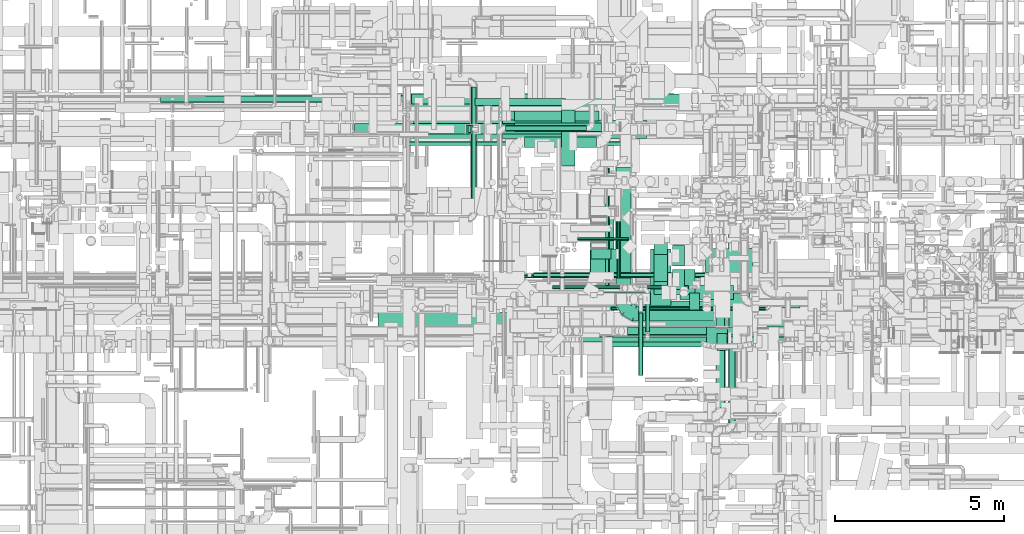
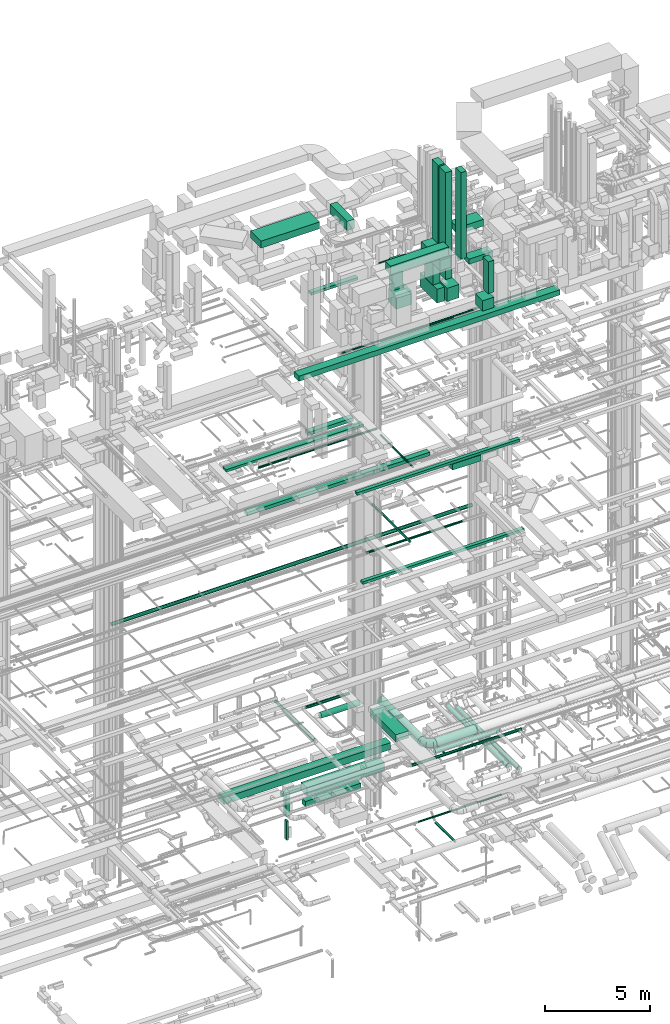
# One storey, part 43 of 337: 51 flow segments, 1 flow fitting.
"""IFC2X3 building model written with IfcOpenShell, lengths in millimetres."""

from ifc_helpers import new_model, entity, si_unit, converted_unit, derived_unit, direction, frame, origin, origin_2d_with_axis, place, context, subcontext, project, spatial, rectangle, circle, extrude, faceted_brep, source, transform, mapped, material, type_object, type_shapes, element, save


model = new_model("IFC2X3")

# Units and contexts
model_context = context("Model", 3, precision=0.01, world=origin(), true_north=direction((6.12303176911189e-17, 1.0)))
body_context = subcontext(model_context, "Body", "Model", "MODEL_VIEW")
ifc_project = project(units=[si_unit("LENGTHUNIT", "METRE", prefix="MILLI"), si_unit("AREAUNIT", "SQUARE_METRE"), si_unit("VOLUMEUNIT", "CUBIC_METRE"), converted_unit("PLANEANGLEUNIT", "DEGREE", entity("IfcRatioMeasure", 0.0174532925199433), si_unit("PLANEANGLEUNIT", "RADIAN"), dimensions=[0, 0, 0, 0, 0, 0, 0]), si_unit("MASSUNIT", "GRAM", prefix="KILO"), derived_unit("MASSDENSITYUNIT", [(si_unit("MASSUNIT", "GRAM", prefix="KILO"), 1), (si_unit("LENGTHUNIT", "METRE"), -3)]), derived_unit("MOMENTOFINERTIAUNIT", [(si_unit("LENGTHUNIT", "METRE"), 4)]), si_unit("TIMEUNIT", "SECOND"), si_unit("FREQUENCYUNIT", "HERTZ"), si_unit("THERMODYNAMICTEMPERATUREUNIT", "DEGREE_CELSIUS"), derived_unit("THERMALTRANSMITTANCEUNIT", [(si_unit("MASSUNIT", "GRAM", prefix="KILO"), 1), (si_unit("THERMODYNAMICTEMPERATUREUNIT", "KELVIN"), -1), (si_unit("TIMEUNIT", "SECOND"), -3)]), derived_unit("VOLUMETRICFLOWRATEUNIT", [(si_unit("LENGTHUNIT", "METRE"), 3), (si_unit("TIMEUNIT", "SECOND"), -1)]), derived_unit("MASSFLOWRATEUNIT", [(si_unit("MASSUNIT", "GRAM", prefix="KILO"), 1), (si_unit("TIMEUNIT", "SECOND"), -1)]), derived_unit("ROTATIONALFREQUENCYUNIT", [(si_unit("TIMEUNIT", "SECOND"), -1)]), si_unit("ELECTRICCURRENTUNIT", "AMPERE"), si_unit("ELECTRICVOLTAGEUNIT", "VOLT"), si_unit("POWERUNIT", "WATT"), si_unit("FORCEUNIT", "NEWTON", prefix="KILO"), si_unit("ILLUMINANCEUNIT", "LUX"), si_unit("LUMINOUSFLUXUNIT", "LUMEN"), si_unit("LUMINOUSINTENSITYUNIT", "CANDELA"), derived_unit("USERDEFINED", [(si_unit("MASSUNIT", "GRAM", prefix="KILO"), -1), (si_unit("LENGTHUNIT", "METRE"), -2), (si_unit("TIMEUNIT", "SECOND"), 3), (si_unit("LUMINOUSFLUXUNIT", "LUMEN"), 1)]), derived_unit("LINEARVELOCITYUNIT", [(si_unit("LENGTHUNIT", "METRE"), 1), (si_unit("TIMEUNIT", "SECOND"), -1)]), si_unit("PRESSUREUNIT", "PASCAL"), derived_unit("USERDEFINED", [(si_unit("LENGTHUNIT", "METRE"), -2), (si_unit("MASSUNIT", "GRAM", prefix="KILO"), 1), (si_unit("TIMEUNIT", "SECOND"), -2)]), derived_unit("LINEARFORCEUNIT", [(si_unit("MASSUNIT", "GRAM", prefix="KILO"), 1), (si_unit("LENGTHUNIT", "METRE"), 1), (si_unit("TIMEUNIT", "SECOND"), -2), (si_unit("LENGTHUNIT", "METRE"), -1)]), derived_unit("PLANARFORCEUNIT", [(si_unit("MASSUNIT", "GRAM", prefix="KILO"), 1), (si_unit("LENGTHUNIT", "METRE"), 1), (si_unit("TIMEUNIT", "SECOND"), -2), (si_unit("LENGTHUNIT", "METRE"), -2)])], contexts=[model_context])

# Site, building, storey
site_placement = place(None, origin())
site = spatial("IfcSite", under=ifc_project, at=site_placement, CompositionType="ELEMENT")
building_placement = place(site_placement, origin())
building = spatial("IfcBuilding", under=site, at=building_placement, CompositionType="ELEMENT")
storey_placement = place(building_placement, origin())
storey = spatial("IfcBuildingStorey", under=building, at=storey_placement, CompositionType="ELEMENT", Elevation=0.0)

# Flow segments
duct_segment_type_1 = type_object("IfcDuctSegmentType", PredefinedType="NOTDEFINED")
flow_segment_1_placement = place(storey_placement, frame((42470.0, 15248.96, -1700.0)))
element("IfcFlowSegment", 1, at=flow_segment_1_placement, inside=storey, type_object=duct_segment_type_1, context=body_context, shape_type="SweptSolid", body=[
    extrude(rectangle(XDim=2675.80214650384, YDim=200.0, at=origin_2d_with_axis()), frame((1337.9, 100.0, 0.0)), (0.0, 0.0, 1.0), 200.0),
])
flow_segment_2_placement = place(storey_placement, frame((39195.61, 15099.1, -900.0)))
element("IfcFlowSegment", 2, at=flow_segment_2_placement, inside=storey, type_object=duct_segment_type_1, context=body_context, shape_type="SweptSolid", body=[
    extrude(rectangle(XDim=9156.58602500004, YDim=500.000000000001, at=origin_2d_with_axis()), frame((4578.29, 250.0, 0.0)), (0.0, 0.0, 1.0), 400.0),
])
flow_segment_3_placement = place(storey_placement, frame((43282.46, 14273.39, -1350.0)))
element("IfcFlowSegment", 3, at=flow_segment_3_placement, inside=storey, type_object=duct_segment_type_1, context=body_context, shape_type="SweptSolid", body=[
    extrude(rectangle(XDim=4253.41533400006, YDim=550.000000000001, at=origin_2d_with_axis()), frame((2126.71, 275.0, 0.0)), (0.0, 0.0, 1.0), 500.0),
])
flow_segment_4_placement = place(storey_placement, frame((43257.3, 14398.39, -2015.0)))
element("IfcFlowSegment", 4, at=flow_segment_4_placement, inside=storey, type_object=duct_segment_type_1, context=body_context, shape_type="SweptSolid", body=[
    extrude(rectangle(XDim=3052.89212750001, YDim=299.999999999999, at=origin_2d_with_axis()), frame((1526.45, 150.0, 0.0), z_axis=(0.0, 0.0, 1.0), x_axis=(-1.0, 0.0, 0.0)), (0.0, 0.0, 1.0), 300.0),
])
flow_segment_5_placement = place(storey_placement, frame((42214.6, 14423.39, -2250.0)))
element("IfcFlowSegment", 5, at=flow_segment_5_placement, inside=storey, type_object=duct_segment_type_1, context=body_context, shape_type="SweptSolid", body=[
    extrude(rectangle(XDim=200.000000000007, YDim=249.999999999999, at=origin_2d_with_axis()), frame((100.0, 125.0, 0.0)), (0.0, 0.0, 1.0), 1380.00015000002),
])
flow_segment_6_placement = place(storey_placement, frame((42264.6, 14448.39, -3658.0)))
element("IfcFlowSegment", 6, at=flow_segment_6_placement, inside=storey, type_object=duct_segment_type_1, context=body_context, shape_type="SweptSolid", body=[
    extrude(rectangle(XDim=99.9999999999946, YDim=200.0, at=origin_2d_with_axis()), frame((50.0, 100.0, 0.0)), (0.0, 0.0, 1.0), 1107.99914362009),
])
flow_segment_7_placement = place(storey_placement, frame((45875.84, 10325.55, 3300.0)))
element("IfcFlowSegment", 7, at=flow_segment_7_placement, inside=storey, type_object=duct_segment_type_1, context=body_context, shape_type="SweptSolid", body=[
    extrude(rectangle(XDim=2470.69245604743, YDim=699.999999999997, at=origin_2d_with_axis()), frame((350.0, 1235.35, 0.0), z_axis=(0.0, 0.0, 1.0), x_axis=(0.0, -1.0, 0.0)), (0.0, 0.0, 1.0), 400.0),
])
flow_segment_8_placement = place(storey_placement, frame((48528.65, 9525.31, 18620.0)))
element("IfcFlowSegment", 8, at=flow_segment_8_placement, inside=storey, type_object=duct_segment_type_1, context=body_context, shape_type="SweptSolid", body=[
    extrude(rectangle(XDim=1571.37718674914, YDim=400.0, at=origin_2d_with_axis()), frame((785.69, 200.0, 0.0)), (0.0, 0.0, 1.0), 349.999999999998),
])
flow_segment_9_placement = place(storey_placement, frame((43149.84, 9270.12, 19200.0)))
element("IfcFlowSegment", 9, at=flow_segment_9_placement, inside=storey, type_object=duct_segment_type_1, context=body_context, shape_type="SweptSolid", body=[
    extrude(rectangle(XDim=8920.00000000017, YDim=200.0, at=origin_2d_with_axis()), frame((4460.0, 100.0, 0.0)), (0.0, 0.0, 1.0), 150.000000000001),
])
flow_segment_10_placement = place(storey_placement, frame((42790.56, 8119.63, 14850.0)))
element("IfcFlowSegment", 10, at=flow_segment_10_placement, inside=storey, type_object=duct_segment_type_1, context=body_context, shape_type="SweptSolid", body=[
    extrude(rectangle(XDim=8870.00000000004, YDim=200.0, at=origin_2d_with_axis()), frame((4435.0, 100.0, 0.0)), (0.0, 0.0, 1.0), 150.000000000001),
])
flow_segment_11_placement = place(storey_placement, frame((43645.71, 14788.36, 19125.02)))
element("IfcFlowSegment", 11, at=flow_segment_11_placement, inside=storey, type_object=duct_segment_type_1, context=body_context, shape_type="SweptSolid", body=[
    extrude(rectangle(XDim=2487.18254069487, YDim=300.000000000001, at=origin_2d_with_axis()), frame((1243.59, 150.0, 0.0), z_axis=(0.0, 0.0, 1.0), x_axis=(-1.0, 0.0, 0.0)), (0.0, 0.0, 1.0), 199.999999999998),
])
flow_segment_12_placement = place(storey_placement, frame((40598.03, 15290.0, 15250.0)))
element("IfcFlowSegment", 12, at=flow_segment_12_placement, inside=storey, type_object=duct_segment_type_1, context=body_context, shape_type="SweptSolid", body=[
    extrude(rectangle(XDim=10014.1666094067, YDim=300.000000000001, at=origin_2d_with_axis()), frame((5007.08, 150.0, 0.0), z_axis=(0.0, 0.0, 1.0), x_axis=(-1.0, 0.0, 0.0)), (0.0, 0.0, 1.0), 200.000000000002),
])
flow_segment_13_placement = place(storey_placement, frame((38914.58, 14410.54, 18900.0)))
element("IfcFlowSegment", 13, at=flow_segment_13_placement, inside=storey, type_object=duct_segment_type_1, context=body_context, shape_type="SweptSolid", body=[
    extrude(rectangle(XDim=7566.22150666199, YDim=300.000000000001, at=origin_2d_with_axis()), frame((3783.11, 150.0, 0.0)), (0.0, 0.0, 1.0), 150.000000000001),
])
flow_segment_14_placement = place(storey_placement, frame((43638.94, 14481.21, 27475.0)))
element("IfcFlowSegment", 14, at=flow_segment_14_placement, inside=storey, type_object=duct_segment_type_1, context=body_context, shape_type="SweptSolid", body=[
    extrude(rectangle(XDim=2569.30194846603, YDim=249.999999999999, at=origin_2d_with_axis()), frame((1284.65, 125.0, 0.0)), (0.0, 0.0, 1.0), 150.000000000001),
])
flow_segment_15_placement = place(storey_placement, frame((40645.1, 14089.12, 31500.0)))
element("IfcFlowSegment", 15, at=flow_segment_15_placement, inside=storey, type_object=duct_segment_type_1, context=body_context, shape_type="SweptSolid", body=[
    extrude(rectangle(XDim=3225.210303074, YDim=1000.0, at=origin_2d_with_axis()), frame((1612.61, 500.0, 0.0)), (0.0, 0.0, 1.0), 399.999999999996),
])
flow_segment_16_placement = place(storey_placement, frame((45894.5, 10714.6, 29220.0)))
element("IfcFlowSegment", 16, at=flow_segment_16_placement, inside=storey, type_object=duct_segment_type_1, context=body_context, shape_type="SweptSolid", body=[
    extrude(rectangle(XDim=300.000000000003, YDim=600.000000000002, at=origin_2d_with_axis()), frame((300.0, 150.0, 0.0), z_axis=(0.0, 0.0, 1.0), x_axis=(0.0, -1.0, 0.0)), (0.0, 0.0, 1.0), 1729.99999999999),
])
flow_segment_17_placement = place(storey_placement, frame((45884.94, 10314.6, 28400.0)))
element("IfcFlowSegment", 17, at=flow_segment_17_placement, inside=storey, type_object=duct_segment_type_1, context=body_context, shape_type="SweptSolid", body=[
    extrude(rectangle(XDim=840.0, YDim=700.000000000001, at=origin_2d_with_axis()), frame((420.0, 350.0, 0.0), z_axis=(0.0, 0.0, 1.0), x_axis=(-1.0, 0.0, 0.0)), (0.0, 0.0, 1.0), 800.0),
])
flow_segment_18_placement = place(storey_placement, frame((44955.04, 9223.67, 31400.0)))
element("IfcFlowSegment", 18, at=flow_segment_18_placement, inside=storey, type_object=duct_segment_type_1, context=body_context, shape_type="SweptSolid", body=[
    extrude(rectangle(XDim=3179.96032355474, YDim=500.0, at=origin_2d_with_axis()), frame((1589.98, 250.0, 0.0)), (0.0, 0.0, 1.0), 499.999999999999),
])
flow_segment_19_placement = place(storey_placement, frame((48305.88, 9809.01, 29587.0)))
element("IfcFlowSegment", 19, at=flow_segment_19_placement, inside=storey, type_object=duct_segment_type_1, context=body_context, shape_type="SweptSolid", body=[
    extrude(rectangle(XDim=350.000000000007, YDim=600.0, at=origin_2d_with_axis()), frame((175.0, 300.0, 0.0)), (0.0, 0.0, 1.0), 6200.0),
])
flow_segment_20_placement = place(storey_placement, frame((47755.03, 10053.67, 29320.0)))
element("IfcFlowSegment", 20, at=flow_segment_20_placement, inside=storey, type_object=duct_segment_type_1, context=body_context, shape_type="SweptSolid", body=[
    extrude(rectangle(XDim=800.0, YDim=399.999999999996, at=origin_2d_with_axis()), frame((200.0, 400.0, 0.0), z_axis=(0.0, 0.0, 1.0), x_axis=(0.0, -1.0, 0.0)), (0.0, 0.0, 1.0), 1359.99999999989),
])
flow_segment_21_placement = place(storey_placement, frame((47755.03, 9665.16, 28500.0)))
element("IfcFlowSegment", 21, at=flow_segment_21_placement, inside=storey, type_object=duct_segment_type_1, context=body_context, shape_type="SweptSolid", body=[
    extrude(rectangle(XDim=1603.29352000009, YDim=400.000000000004, at=origin_2d_with_axis()), frame((200.0, 801.65, 0.0), z_axis=(0.0, 0.0, 1.0), x_axis=(0.0, -1.0, 0.0)), (0.0, 0.0, 1.0), 800.0),
])
flow_segment_22_placement = place(storey_placement, frame((48310.88, 9659.01, 28400.0)))
element("IfcFlowSegment", 22, at=flow_segment_22_placement, inside=storey, type_object=duct_segment_type_1, context=body_context, shape_type="SweptSolid", body=[
    extrude(rectangle(XDim=750.0, YDim=659.999999999997, at=origin_2d_with_axis()), frame((330.0, 375.0, 0.0), z_axis=(0.0, 0.0, 1.0), x_axis=(0.0, -1.0, 0.0)), (0.0, 0.0, 1.0), 769.999999999998),
])
flow_segment_23_placement = place(storey_placement, frame((48305.88, 10509.01, 29587.0)))
element("IfcFlowSegment", 23, at=flow_segment_23_placement, inside=storey, type_object=duct_segment_type_1, context=body_context, shape_type="SweptSolid", body=[
    extrude(rectangle(XDim=350.000000000007, YDim=600.0, at=origin_2d_with_axis()), frame((175.0, 300.0, 0.0)), (0.0, 0.0, 1.0), 6200.0),
])
flow_segment_24_placement = place(storey_placement, frame((47655.88, 9190.49, 30700.0)))
element("IfcFlowSegment", 24, at=flow_segment_24_placement, inside=storey, type_object=duct_segment_type_1, context=body_context, shape_type="SweptSolid", body=[
    extrude(rectangle(XDim=1820.00000000001, YDim=600.000000000002, at=origin_2d_with_axis()), frame((300.0, 910.0, 0.0), z_axis=(0.0, 0.0, 1.0), x_axis=(0.0, -1.0, 0.0)), (0.0, 0.0, 1.0), 600.000000000002),
])
flow_segment_25_placement = place(storey_placement, frame((49615.11, 8010.0, 29400.0)))
element("IfcFlowSegment", 25, at=flow_segment_25_placement, inside=storey, type_object=duct_segment_type_1, context=body_context, shape_type="SweptSolid", body=[
    extrude(rectangle(XDim=500.0, YDim=300.000000000001, at=origin_2d_with_axis()), frame((150.0, 250.0, 0.0), z_axis=(0.0, 0.0, 1.0), x_axis=(0.0, -1.0, 0.0)), (0.0, 0.0, 1.0), 1849.9999999999),
])
flow_segment_26_placement = place(storey_placement, frame((49305.11, 8010.0, 28500.0)))
element("IfcFlowSegment", 26, at=flow_segment_26_placement, inside=storey, type_object=duct_segment_type_1, context=body_context, shape_type="SweptSolid", body=[
    extrude(rectangle(XDim=619.999999999998, YDim=700.0, at=origin_2d_with_axis()), frame((310.0, 350.0, 0.0), z_axis=(0.0, 0.0, 1.0), x_axis=(-1.0, 0.0, 0.0)), (0.0, 0.0, 1.0), 600.000000000119),
])
flow_segment_27_placement = place(storey_placement, frame((48805.39, 9213.84, 30950.0)))
element("IfcFlowSegment", 27, at=flow_segment_27_placement, inside=storey, type_object=duct_segment_type_1, context=body_context, shape_type="SweptSolid", body=[
    extrude(rectangle(XDim=499.999999999998, YDim=300.000000000001, at=origin_2d_with_axis()), frame((150.0, 250.0, 0.0), z_axis=(0.0, 0.0, 1.0), x_axis=(0.0, -1.0, 0.0)), (0.0, 0.0, 1.0), 5029.99999999999),
])
flow_segment_28_placement = place(storey_placement, frame((49255.39, 9213.84, 30500.0)))
element("IfcFlowSegment", 28, at=flow_segment_28_placement, inside=storey, type_object=duct_segment_type_1, context=body_context, shape_type="SweptSolid", body=[
    extrude(rectangle(XDim=1319.22169000003, YDim=500.0, at=origin_2d_with_axis()), frame((659.61, 250.0, 0.0), z_axis=(0.0, 0.0, 1.0), x_axis=(-1.0, 0.0, 0.0)), (0.0, 0.0, 1.0), 300.000000000001),
])
flow_segment_29_placement = place(storey_placement, frame((49273.28, 10318.92, 31550.0)))
element("IfcFlowSegment", 29, at=flow_segment_29_placement, inside=storey, type_object=duct_segment_type_1, context=body_context, shape_type="SweptSolid", body=[
    extrude(rectangle(XDim=1410.141595, YDim=700.000000000001, at=origin_2d_with_axis()), frame((705.07, 350.0, 0.0)), (0.0, 0.0, 1.0), 399.999999999996),
])
flow_segment_30_placement = place(storey_placement, frame((39617.06, 8699.98, 27400.0)))
element("IfcFlowSegment", 30, at=flow_segment_30_placement, inside=storey, type_object=duct_segment_type_1, context=body_context, shape_type="SweptSolid", body=[
    extrude(rectangle(XDim=14323.633695998, YDim=449.999999999999, at=origin_2d_with_axis()), frame((7161.82, 225.0, 0.0), z_axis=(0.0, 0.0, 1.0), x_axis=(-1.0, 0.0, 0.0)), (0.0, 0.0, 1.0), 300.000000000001),
])
flow_segment_31_placement = place(storey_placement, frame((45022.31, 13464.41, 31350.0)))
element("IfcFlowSegment", 31, at=flow_segment_31_placement, inside=storey, type_object=duct_segment_type_1, context=body_context, shape_type="SweptSolid", body=[
    extrude(rectangle(XDim=1652.8586706448, YDim=399.999999999996, at=origin_2d_with_axis()), frame((200.0, 826.43, 0.0), z_axis=(0.0, 0.0, 1.0), x_axis=(0.0, 1.0, 0.0)), (0.0, 0.0, 1.0), 549.999999999996),
])
duct_segment_type_2 = type_object("IfcDuctSegmentType", PredefinedType="NOTDEFINED")
flow_segment_32_placement = place(storey_placement, frame((47304.85, 7271.24, -1224.1)))
element("IfcFlowSegment", 32, at=flow_segment_32_placement, inside=storey, type_object=duct_segment_type_2, context=body_context, shape_type="SweptSolid", body=[
    extrude(circle(Radius=62.5, at=origin_2d_with_axis()), frame((64.1, 0.0, 64.1), z_axis=(0.0, 1.0, 0.0), x_axis=(1.0, 0.0, 0.0)), (0.0, 0.0, 1.0), 1845.13179470331),
])
flow_segment_33_placement = place(storey_placement, frame((46485.51, 9193.41, -951.6)))
element("IfcFlowSegment", 33, at=flow_segment_33_placement, inside=storey, type_object=duct_segment_type_2, context=body_context, shape_type="SweptSolid", body=[
    extrude(circle(Radius=50.0, at=origin_2d_with_axis()), frame((0.0, 51.6, 51.6), z_axis=(1.0, 0.0, 0.0), x_axis=(0.0, 1.0, 0.0)), (0.0, 0.0, 1.0), 4568.00816944938),
])
flow_segment_34_placement = place(storey_placement, frame((46976.82, 8460.07, 3298.4)))
element("IfcFlowSegment", 34, at=flow_segment_34_placement, inside=storey, type_object=duct_segment_type_2, context=body_context, shape_type="SweptSolid", body=[
    extrude(circle(Radius=125.0, at=origin_2d_with_axis()), frame((0.0, 126.6, 126.6), z_axis=(1.0, 0.0, 0.0), x_axis=(0.0, 1.0, 0.0)), (0.0, 0.0, 1.0), 3554.57947317912),
])
flow_segment_35_placement = place(storey_placement, frame((33194.89, 15333.25, 11368.4)))
element("IfcFlowSegment", 35, at=flow_segment_35_placement, inside=storey, type_object=duct_segment_type_2, context=body_context, shape_type="SweptSolid", body=[
    extrude(circle(Radius=100.0, at=origin_2d_with_axis()), frame((0.0, 101.6, 101.6), z_axis=(1.0, 0.0, 0.0), x_axis=(0.0, 1.0, 0.0)), (0.0, 0.0, 1.0), 19815.0000000002),
])
flow_segment_36_placement = place(storey_placement, frame((45599.62, 8260.92, 3158.4)))
element("IfcFlowSegment", 36, at=flow_segment_36_placement, inside=storey, type_object=duct_segment_type_2, context=body_context, shape_type="SweptSolid", body=[
    extrude(circle(Radius=80.0, at=origin_2d_with_axis()), frame((0.0, 81.6, 81.6), z_axis=(1.0, 0.0, 0.0), x_axis=(0.0, -1.0, 0.0)), (0.0, 0.0, 1.0), 6023.72583002029),
])
flow_segment_37_placement = place(storey_placement, frame((46628.62, 9558.65, 3273.4)))
element("IfcFlowSegment", 37, at=flow_segment_37_placement, inside=storey, type_object=duct_segment_type_2, context=body_context, shape_type="SweptSolid", body=[
    extrude(circle(Radius=225.0, at=origin_2d_with_axis()), frame((226.6, 0.0, 226.6), z_axis=(0.0, 1.0, 0.0), x_axis=(-1.0, 0.0, 0.0)), (0.0, 0.0, 1.0), 3858.77143434905),
])
flow_segment_38_placement = place(storey_placement, frame((47305.22, 8882.05, 3273.4)))
element("IfcFlowSegment", 38, at=flow_segment_38_placement, inside=storey, type_object=duct_segment_type_2, context=body_context, shape_type="SweptSolid", body=[
    extrude(circle(Radius=225.0, at=origin_2d_with_axis()), frame((0.0, 226.6, 226.6), z_axis=(1.0, 0.0, 0.0), x_axis=(0.0, 1.0, 0.0)), (0.0, 0.0, 1.0), 2205.00000000359),
])
flow_segment_39_placement = place(storey_placement, frame((42357.57, 12072.65, 3468.4)))
element("IfcFlowSegment", 39, at=flow_segment_39_placement, inside=storey, type_object=duct_segment_type_2, context=body_context, shape_type="SweptSolid", body=[
    extrude(circle(Radius=80.0, at=origin_2d_with_axis()), frame((81.6, 0.0, 81.6), z_axis=(0.0, 1.0, 0.0), x_axis=(1.0, 0.0, 0.0)), (0.0, 0.0, 1.0), 3713.75000000001),
])
flow_segment_40_placement = place(storey_placement, frame((43931.18, 14001.85, 3040.9)))
element("IfcFlowSegment", 40, at=flow_segment_40_placement, inside=storey, type_object=duct_segment_type_2, context=body_context, shape_type="SweptSolid", body=[
    extrude(circle(Radius=157.5, at=origin_2d_with_axis()), frame((0.0, 159.1, 159.1), z_axis=(1.0, 0.0, 0.0), x_axis=(0.0, -1.0, 0.0)), (0.0, 0.0, 1.0), 2125.40307793713),
])
flow_segment_41_placement = place(storey_placement, frame((43370.25, 14487.28, 3518.4)))
element("IfcFlowSegment", 41, at=flow_segment_41_placement, inside=storey, type_object=duct_segment_type_2, context=body_context, shape_type="SweptSolid", body=[
    extrude(circle(Radius=80.0, at=origin_2d_with_axis()), frame((0.0, 81.6, 81.6), z_axis=(1.0, 0.0, 0.0), x_axis=(0.0, 1.0, 0.0)), (0.0, 0.0, 1.0), 2396.39610306792),
])
flow_segment_42_placement = place(storey_placement, frame((40527.38, 14061.95, 18715.9)))
element("IfcFlowSegment", 42, at=flow_segment_42_placement, inside=storey, type_object=duct_segment_type_2, context=body_context, shape_type="SweptSolid", body=[
    extrude(circle(Radius=62.5, at=origin_2d_with_axis()), frame((0.0, 64.1, 64.1), z_axis=(1.0, 0.0, 0.0), x_axis=(0.0, -1.0, 0.0)), (0.0, 0.0, 1.0), 6510.00000000002),
])
flow_segment_43_placement = place(storey_placement, frame((46668.1, 10157.12, 18998.4)))
element("IfcFlowSegment", 43, at=flow_segment_43_placement, inside=storey, type_object=duct_segment_type_2, context=body_context, shape_type="SweptSolid", body=[
    extrude(circle(Radius=50.0, at=origin_2d_with_axis()), frame((51.6, 0.0, 51.6), z_axis=(0.0, 1.0, 0.0), x_axis=(1.0, 0.0, 0.0)), (0.0, 0.0, 1.0), 3079.99999999995),
])
flow_segment_44_placement = place(storey_placement, frame((46323.13, 9840.69, 14975.9)))
element("IfcFlowSegment", 44, at=flow_segment_44_placement, inside=storey, type_object=duct_segment_type_2, context=body_context, shape_type="SweptSolid", body=[
    extrude(circle(Radius=62.5, at=origin_2d_with_axis()), frame((64.1, 0.0, 64.1), z_axis=(0.0, 1.0, 0.0), x_axis=(1.0, 0.0, 0.0)), (0.0, 0.0, 1.0), 3555.0),
])
flow_segment_45_placement = place(storey_placement, frame((44207.03, 10182.2, 14835.9)))
element("IfcFlowSegment", 45, at=flow_segment_45_placement, inside=storey, type_object=duct_segment_type_2, context=body_context, shape_type="SweptSolid", body=[
    extrude(circle(Radius=62.5, at=origin_2d_with_axis()), frame((0.0, 64.1, 64.1), z_axis=(1.0, 0.0, 0.0), x_axis=(0.0, -1.0, 0.0)), (0.0, 0.0, 1.0), 5263.0),
])
flow_segment_46_placement = place(storey_placement, frame((45506.65, 11251.15, 30551.83)))
element("IfcFlowSegment", 46, at=flow_segment_46_placement, inside=storey, type_object=duct_segment_type_2, context=body_context, shape_type="SweptSolid", body=[
    extrude(circle(Radius=50.0, at=origin_2d_with_axis()), frame((0.0, 51.6, 51.6), z_axis=(1.0, 0.0, 0.0), x_axis=(0.0, 1.0, 0.0)), (0.0, 0.0, 1.0), 1494.99442672084),
])
flow_segment_47_placement = place(storey_placement, frame((47500.5, 8554.29, 3035.9)))
element("IfcFlowSegment", 47, at=flow_segment_47_placement, inside=storey, type_object=duct_segment_type_2, context=body_context, shape_type="SweptSolid", body=[
    extrude(circle(Radius=62.5, at=origin_2d_with_axis()), frame((64.1, 0.0, 64.1), z_axis=(0.0, 1.0, 0.0), x_axis=(1.0, 0.0, 0.0)), (0.0, 0.0, 1.0), 1143.22330470338),
])
flow_segment_48_placement = place(storey_placement, frame((42812.73, 10148.35, 26948.4)))
element("IfcFlowSegment", 48, at=flow_segment_48_placement, inside=storey, type_object=duct_segment_type_2, context=body_context, shape_type="SweptSolid", body=[
    extrude(circle(Radius=50.0, at=origin_2d_with_axis()), frame((0.0, 51.6, 51.6), z_axis=(1.0, 0.0, 0.0), x_axis=(0.0, -1.0, 0.0)), (0.0, 0.0, 1.0), 10868.3051866036),
])
flow_segment_49_placement = place(storey_placement, frame((44761.37, 9829.93, 27148.4)))
element("IfcFlowSegment", 49, at=flow_segment_49_placement, inside=storey, type_object=duct_segment_type_2, context=body_context, shape_type="SweptSolid", body=[
    extrude(circle(Radius=50.0, at=origin_2d_with_axis()), frame((0.0, 51.6, 51.6), z_axis=(1.0, 0.0, 0.0), x_axis=(0.0, -1.0, 0.0)), (0.0, 0.0, 1.0), 4019.29864376276),
])
flow_segment_50_placement = place(storey_placement, frame((49600.95, 6313.16, 2873.4)))
element("IfcFlowSegment", 50, at=flow_segment_50_placement, inside=storey, type_object=duct_segment_type_2, context=body_context, shape_type="SweptSolid", body=[
    extrude(circle(Radius=125.0, at=origin_2d_with_axis()), frame((126.6, 0.0, 126.6), z_axis=(0.0, 1.0, 0.0), x_axis=(1.0, 0.0, 0.0)), (0.0, 0.0, 1.0), 5719.04408657297),
])
flow_segment_51_placement = place(storey_placement, frame((49960.95, 5877.42, 2898.4)))
element("IfcFlowSegment", 51, at=flow_segment_51_placement, inside=storey, type_object=duct_segment_type_2, context=body_context, shape_type="SweptSolid", body=[
    extrude(circle(Radius=100.0, at=origin_2d_with_axis()), frame((101.6, 0.0, 101.6), z_axis=(0.0, 1.0, 0.0), x_axis=(-1.0, 0.0, 0.0)), (0.0, 0.0, 1.0), 5838.77508624615),
])

# Flow fitting
ifc_material = material()
duct_fitting_type = type_object("IfcDuctFittingType", PredefinedType="NOTDEFINED", material=ifc_material)
shared_shape = source(origin(), body_context, "Body", "Brep", [
    faceted_brep([(-450.0, 0.0, -225.0), (-450.0, -50.07, -219.36), (-450.0, -97.62, -202.72), (-450.0, -140.29, -175.91), (-450.0, -175.91, -140.29), (-450.0, -202.72, -97.62), (-450.0, -219.36, -50.07), (-450.0, -225.0, 0.0), (-450.0, -219.36, 50.07), (-450.0, -202.72, 97.62), (-450.0, -175.91, 140.29), (-450.0, -140.29, 175.91), (-450.0, -97.62, 202.72), (-450.0, -50.07, 219.36), (-450.0, 0.0, 225.0), (-450.0, 50.07, 219.36), (-450.0, 97.62, 202.72), (-450.0, 140.29, 175.91), (-450.0, 175.91, 140.29), (-450.0, 202.72, 97.62), (-450.0, 219.36, 50.07), (-450.0, 225.0, 0.0), (-450.0, 219.36, -50.07), (-450.0, 202.72, -97.62), (-450.0, 175.91, -140.29), (-450.0, 140.29, -175.91), (-450.0, 97.62, -202.72), (-450.0, 50.07, -219.36), (-329.42, 0.0, 225.0), (-342.84, 50.07, 219.36), (-355.58, 97.62, 202.72), (-367.01, 140.29, 175.91), (-376.56, 175.91, 140.29), (-383.74, 202.72, 97.62), (-388.2, 219.36, 50.07), (-389.71, 225.0, 0.0), (-388.2, 219.36, -50.07), (-383.74, 202.72, -97.62), (-376.56, 175.91, -140.29), (-367.01, 140.29, -175.91), (-355.58, 97.62, -202.72), (-342.84, 50.07, -219.36), (-329.42, 0.0, -225.0), (-316.01, -50.07, -219.36), (-303.26, -97.62, -202.72), (-291.83, -140.29, -175.91), (-282.29, -175.91, -140.29), (-275.1, -202.72, -97.62), (-270.65, -219.36, -50.07), (-269.13, -225.0, 0.0), (-270.65, -219.36, 50.07), (-275.1, -202.72, 97.62), (-282.29, -175.91, 140.29), (-291.83, -140.29, 175.91), (-303.26, -97.62, 202.72), (-316.01, -50.07, 219.36), (-120.58, 120.58, 225.0), (-157.23, 157.23, 219.36), (-192.04, 192.04, 202.72), (-223.27, 223.27, 175.91), (-249.35, 249.35, 140.29), (-268.98, 268.98, 97.62), (-281.16, 281.16, 50.07), (-285.29, 285.29, 0.0), (-281.16, 281.16, -50.07), (-268.98, 268.98, -97.62), (-249.35, 249.35, -140.29), (-223.27, 223.27, -175.91), (-192.04, 192.04, -202.72), (-157.23, 157.23, -219.36), (-120.58, 120.58, -225.0), (-83.93, 83.93, -219.36), (-49.11, 49.11, -202.72), (-17.88, 17.88, -175.91), (8.2, -8.2, -140.29), (27.82, -27.82, -97.62), (40.0, -40.0, -50.07), (44.13, -44.13, 0.0), (40.0, -40.0, 50.07), (27.82, -27.82, 97.62), (8.2, -8.2, 140.29), (-17.88, 17.88, 175.91), (-49.11, 49.11, 202.72), (-83.93, 83.93, 219.36), (0.0, 329.42, 225.0), (-50.07, 342.84, 219.36), (-97.62, 355.58, 202.72), (-140.29, 367.01, 175.91), (-175.91, 376.56, 140.29), (-202.72, 383.74, 97.62), (-219.36, 388.2, 50.07), (-225.0, 389.71, 0.0), (-219.36, 388.2, -50.07), (-202.72, 383.74, -97.62), (-175.91, 376.56, -140.29), (-140.29, 367.01, -175.91), (-97.62, 355.58, -202.72), (-50.07, 342.84, -219.36), (0.0, 329.42, -225.0), (50.07, 316.01, -219.36), (97.62, 303.26, -202.72), (140.29, 291.83, -175.91), (175.91, 282.29, -140.29), (202.72, 275.1, -97.62), (219.36, 270.65, -50.07), (225.0, 269.13, 0.0), (219.36, 270.65, 50.07), (202.72, 275.1, 97.62), (175.91, 282.29, 140.29), (140.29, 291.83, 175.91), (97.62, 303.26, 202.72), (50.07, 316.01, 219.36), (-50.07, 450.0, -219.36), (-97.62, 450.0, -202.72), (-140.29, 450.0, -175.91), (-175.91, 450.0, -140.29), (-202.72, 450.0, -97.62), (-219.36, 450.0, -50.07), (-225.0, 450.0, 0.0), (-219.36, 450.0, 50.07), (-202.72, 450.0, 97.62), (-175.91, 450.0, 140.29), (-140.29, 450.0, 175.91), (-97.62, 450.0, 202.72), (-50.07, 450.0, 219.36), (0.0, 450.0, 225.0), (50.07, 450.0, 219.36), (97.62, 450.0, 202.72), (140.29, 450.0, 175.91), (175.91, 450.0, 140.29), (202.72, 450.0, 97.62), (219.36, 450.0, 50.07), (225.0, 450.0, 0.0), (219.36, 450.0, -50.07), (202.72, 450.0, -97.62), (175.91, 450.0, -140.29), (140.29, 450.0, -175.91), (97.62, 450.0, -202.72), (50.07, 450.0, -219.36), (0.0, 450.0, -225.0)], [[[0, 1, 2, 3, 4, 5, 6, 7, 8, 9, 10, 11, 12, 13, 14, 15, 16, 17, 18, 19, 20, 21, 22, 23, 24, 25, 26, 27]], [[28, 29, 15, 14]], [[30, 31, 17, 16]], [[29, 30, 16, 15]], [[31, 32, 18, 17]], [[32, 33, 19, 18]], [[34, 35, 21, 20]], [[33, 34, 20, 19]], [[35, 36, 22, 21]], [[37, 38, 24, 23]], [[36, 37, 23, 22]], [[38, 39, 25, 24]], [[39, 40, 26, 25]], [[41, 42, 0, 27]], [[40, 41, 27, 26]], [[1, 0, 42, 43]], [[43, 44, 2, 1]], [[45, 3, 2, 44]], [[45, 46, 4, 3]], [[5, 4, 46, 47]], [[47, 48, 6, 5]], [[49, 7, 6, 48]], [[7, 49, 50, 8]], [[8, 50, 51, 9]], [[9, 51, 52, 10]], [[52, 53, 11, 10]], [[11, 53, 54, 12]], [[12, 54, 55, 13]], [[13, 55, 28, 14]], [[56, 57, 29, 28]], [[58, 59, 31, 30]], [[57, 58, 30, 29]], [[59, 60, 32, 31]], [[60, 61, 33, 32]], [[62, 63, 35, 34]], [[61, 62, 34, 33]], [[63, 64, 36, 35]], [[65, 66, 38, 37]], [[64, 65, 37, 36]], [[66, 67, 39, 38]], [[67, 68, 40, 39]], [[69, 70, 42, 41]], [[68, 69, 41, 40]], [[43, 42, 70, 71]], [[71, 72, 44, 43]], [[73, 45, 44, 72]], [[73, 74, 46, 45]], [[47, 46, 74, 75]], [[75, 76, 48, 47]], [[77, 49, 48, 76]], [[50, 49, 77, 78]], [[51, 50, 78, 79]], [[52, 51, 79, 80]], [[80, 81, 53, 52]], [[54, 53, 81, 82]], [[55, 54, 82, 83]], [[28, 55, 83, 56]], [[84, 85, 57, 56]], [[86, 87, 59, 58]], [[85, 86, 58, 57]], [[87, 88, 60, 59]], [[88, 89, 61, 60]], [[90, 91, 63, 62]], [[89, 90, 62, 61]], [[91, 92, 64, 63]], [[93, 94, 66, 65]], [[92, 93, 65, 64]], [[94, 95, 67, 66]], [[95, 96, 68, 67]], [[97, 98, 70, 69]], [[96, 97, 69, 68]], [[71, 70, 98, 99]], [[99, 100, 72, 71]], [[101, 73, 72, 100]], [[101, 102, 74, 73]], [[75, 74, 102, 103]], [[103, 104, 76, 75]], [[105, 77, 76, 104]], [[78, 77, 105, 106]], [[79, 78, 106, 107]], [[80, 79, 107, 108]], [[108, 109, 81, 80]], [[82, 81, 109, 110]], [[83, 82, 110, 111]], [[56, 83, 111, 84]], [[112, 113, 114, 115, 116, 117, 118, 119, 120, 121, 122, 123, 124, 125, 126, 127, 128, 129, 130, 131, 132, 133, 134, 135, 136, 137, 138, 139]], [[85, 84, 125, 124]], [[86, 85, 124, 123]], [[87, 86, 123, 122]], [[122, 121, 88, 87]], [[89, 88, 121, 120]], [[90, 89, 120, 119]], [[91, 90, 119, 118]], [[91, 118, 117, 92]], [[116, 115, 94, 93]], [[92, 117, 116, 93]], [[115, 114, 95, 94]], [[95, 114, 113, 96]], [[96, 113, 112, 97]], [[97, 112, 139, 98]], [[98, 139, 138, 99]], [[99, 138, 137, 100]], [[100, 137, 136, 101]], [[136, 135, 102, 101]], [[102, 135, 134, 103]], [[103, 134, 133, 104]], [[104, 133, 132, 105]], [[106, 105, 132, 131]], [[107, 106, 131, 130]], [[108, 107, 130, 129]], [[129, 128, 109, 108]], [[110, 109, 128, 127]], [[111, 110, 127, 126]], [[84, 111, 126, 125]]]),
])
type_shapes(duct_fitting_type, [shared_shape])
flow_fitting_placement = place(storey_placement, frame((46855.22, 9108.65, 3499.99), z_axis=(0.0, 0.0, 1.0), x_axis=(0.0, -1.0, 0.0)))
element("IfcFlowFitting", 52, at=flow_fitting_placement, inside=storey, type_object=duct_fitting_type, material=ifc_material, context=body_context, shape_type="MappedRepresentation", body=[
    mapped(shared_shape, transform((0.0, 0.0, 0.0), scale=1.0)),
])

save(model, "model.ifc")
